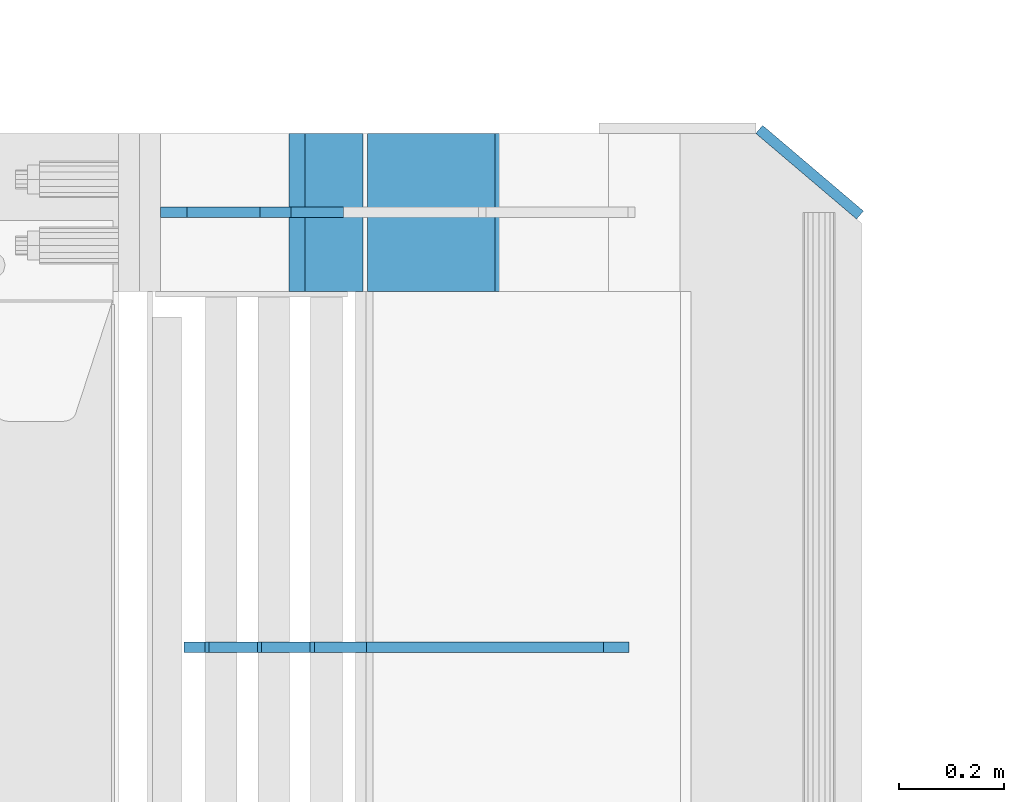
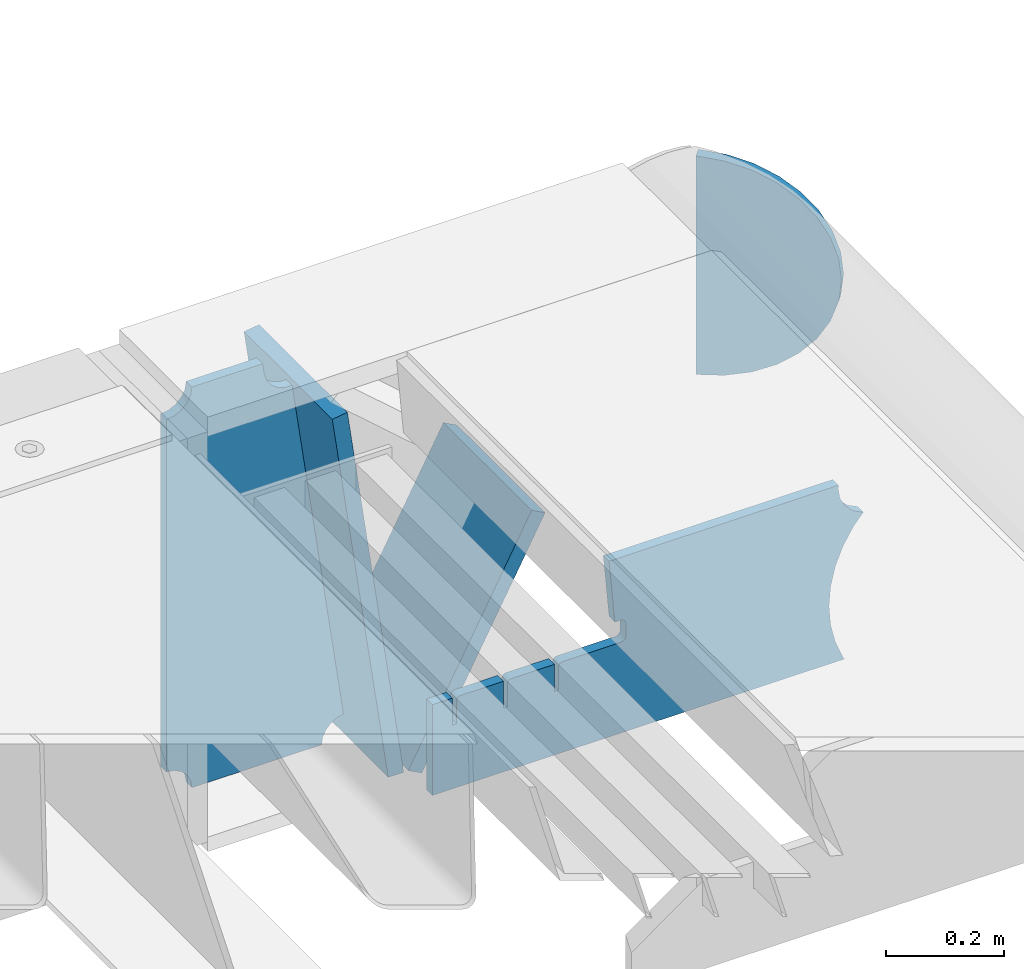
# One storey, part 194 of 208: 5 plates.
"""IFC2X3 building model written with IfcOpenShell, lengths in millimetres."""

from ifc_helpers import new_model, si_unit, frame, origin_with_axes, place, context, subcontext, project, spatial, faceted_brep, material, type_object, element, save


model = new_model("IFC2X3")

# Units and contexts
model_context = context("Model", 3, precision=1e-05, world=origin_with_axes())
body_context = subcontext(model_context, "Body", "Model", "MODEL_VIEW")
ifc_project = project(units=[si_unit("LENGTHUNIT", "METRE", prefix="MILLI"), si_unit("AREAUNIT", "SQUARE_METRE"), si_unit("VOLUMEUNIT", "CUBIC_METRE"), si_unit("MASSUNIT", "GRAM", prefix="KILO"), si_unit("TIMEUNIT", "SECOND"), si_unit("PLANEANGLEUNIT", "RADIAN"), si_unit("SOLIDANGLEUNIT", "STERADIAN"), si_unit("THERMODYNAMICTEMPERATUREUNIT", "DEGREE_CELSIUS"), si_unit("LUMINOUSINTENSITYUNIT", "LUMEN")], contexts=[model_context])

# Site, building, storey
site_placement = place(None, origin_with_axes())
site = spatial("IfcSite", under=ifc_project, at=site_placement, CompositionType="ELEMENT")
building_placement = place(site_placement, origin_with_axes())
building = spatial("IfcBuilding", under=site, at=building_placement, Name="Standard", CompositionType="ELEMENT")
storey_placement = place(building_placement, origin_with_axes())
storey = spatial("IfcBuildingStorey", under=building, at=storey_placement, Name="Undefined", CompositionType="ELEMENT", Elevation=0.0)

# Plates
ifc_material = material(Name="STEEL/S355N")
plate_type_1 = type_object("IfcPlateType", PredefinedType="NOTDEFINED")
plate_1_placement = place(storey_placement, frame((-25183.8519322781, 6150.000000001, -862.083788721732), z_axis=(-0.139173011053008, 0.0, 0.990268081377179), x_axis=(0.0, -1.0, 0.0)))
element("IfcPlate", 1, at=plate_1_placement, inside=storey, type_object=plate_type_1, material=ifc_material, context=body_context, shape_type="Brep", body=[
    faceted_brep([(1.00411057246674e-09, 14.9994702460535, -0.00376939767375006), (300.0, 15.0, 0.0), (300.0, -15.0, 4.21237841386846), (0.0, -15.0, 4.21237841386846), (0.0, -14.9999999999964, 792.0), (300.0, -14.9999999999964, 792.0), (300.0, 15.0, 792.0), (0.0, 15.0, 792.0)], [[[0, 1, 2, 3]], [[4, 5, 6, 7]], [[4, 7, 0, 3]], [[5, 4, 3, 2]], [[6, 5, 2, 1]], [[7, 6, 1, 0]]]),
])
plate_2_placement = place(storey_placement, frame((-25146.7531990434, 6150.000000001, -867.038754739308), z_axis=(0.469471552246176, 0.0, 0.882947598462992), x_axis=(0.0, -1.0, 0.0)))
element("IfcPlate", 2, at=plate_2_placement, inside=storey, type_object=plate_type_1, material=ifc_material, context=body_context, shape_type="Brep", body=[
    faceted_brep([(0.0, -15.0, 0.0), (0.0, -15.0000000000036, 514.999999999996), (0.0, 14.9999999999964, 514.999999999998), (0.0, 15.0, 0.0), (300.0, -15.0000000000036, 514.999999999996), (300.0, 14.9999999999964, 514.999999999998), (300.0, -15.0, 0.0), (300.0, 15.0, 0.0)], [[[0, 1, 2, 3]], [[1, 4, 5, 2]], [[4, 6, 7, 5]], [[6, 0, 3, 7]], [[5, 7, 3, 2]], [[6, 4, 1, 0]]]),
])
plate_type_2 = type_object("IfcPlateType", PredefinedType="NOTDEFINED")
plate_3_placement = place(storey_placement, frame((-25314.001170111, 6000.0, -30.0000000032531), z_axis=(0.0, 0.0, -1.0), x_axis=(-1.0, 0.0, 0.0)))
element("IfcPlate", 3, at=plate_3_placement, inside=storey, type_object=plate_type_2, material=ifc_material, context=body_context, shape_type="Brep", body=[
    faceted_brep([(-9.00602409638668, -10.0, 65.0), (-108.137843376921, -10.0, 780.473130459514), (-108.137843376921, 10.0, 780.473130459514), (-9.00602409638668, 10.0, 65.0), (-94.4157884488377, -10.0, 784.433672138112), (-94.4157884488377, 10.0, 784.433672138112), (-82.3732461236723, -10.0, 792.112074067144), (-82.3732461236723, 10.0, 792.112074067144), (-72.9927947992364, -10.0, 802.881837982249), (-72.9927947992364, 10.0, 802.881837982249), (-67.0398068183713, -10.0, 815.864234368775), (-67.0398068183713, 10.0, 815.864234368775), (-65.0, -10.0, 830.0), (-65.0, 10.0, 830.0), (189.0, -10.0, 830.0), (189.0, 10.0, 830.0), (191.447174185243, -10.0, 814.549150281253), (191.447174185243, 10.0, 814.549150281253), (198.549150281251, -10.0, 800.610737385376), (198.549150281251, 10.0, 800.610737385376), (209.610737385377, -10.0, 789.549150281253), (209.610737385377, 10.0, 789.549150281253), (223.549150281251, -10.0, 782.447174185242), (223.549150281251, 10.0, 782.447174185242), (239.0, -10.0, 780.0), (239.0, 10.0, 780.0), (239.0, -10.0, 50.0), (239.0, 10.0, 50.0), (223.549150281251, -10.0, 47.5528258147577), (223.549150281251, 10.0, 47.5528258147577), (209.610737385377, -10.0, 40.4508497187474), (209.610737385377, 10.0, 40.4508497187474), (198.549150281251, -10.0, 29.3892626146237), (198.549150281251, 10.0, 29.3892626146237), (191.447174185243, -10.0, 15.4508497187474), (191.447174185243, 10.0, 15.4508497187474), (189.0, -10.0, 0.0), (189.0, 10.0, 0.0), (50.4776502774184, -10.0, 0.0), (50.4776502774184, 10.0, 0.0), (47.3830020671812, -10.0, 22.3352870825933), (47.3830020671812, 10.0, 22.3352870825933), (42.8384615202776, -10.0, 37.3040735979326), (42.8384615202776, 10.0, 37.3040735979326), (33.8907372011709, -10.0, 50.1358952937587), (33.8907372011709, 10.0, 50.1358952937587), (21.4156947086703, -10.0, 59.5746840579253), (21.4156947086703, 10.0, 59.5746840579253), (6.63447812067898, -10.0, 64.6965054822873), (6.63447812067898, 10.0, 64.6965054822873)], [[[0, 1, 2, 3]], [[1, 4, 5, 2]], [[4, 6, 7, 5]], [[6, 8, 9, 7]], [[8, 10, 11, 9]], [[10, 12, 13, 11]], [[12, 14, 15, 13]], [[14, 16, 17, 15]], [[16, 18, 19, 17]], [[18, 20, 21, 19]], [[20, 22, 23, 21]], [[22, 24, 25, 23]], [[24, 26, 27, 25]], [[26, 28, 29, 27]], [[28, 30, 31, 29]], [[30, 32, 33, 31]], [[32, 34, 35, 33]], [[34, 36, 37, 35]], [[36, 38, 39, 37]], [[38, 40, 41, 39]], [[40, 42, 43, 41]], [[42, 44, 45, 43]], [[44, 46, 47, 45]], [[46, 48, 49, 47]], [[48, 0, 3, 49]], [[5, 7, 9, 11, 13, 15, 17, 19, 21, 23, 25, 27, 29, 31, 33, 35, 37, 39, 41, 43, 45, 47, 49, 3, 2]], [[48, 46, 44, 42, 40, 38, 36, 34, 32, 30, 28, 26, 24, 22, 20, 18, 16, 14, 12, 10, 8, 6, 4, 1, 0]]]),
])
plate_type_3 = type_object("IfcPlateType", PredefinedType="NOTDEFINED")
plate_4_placement = place(storey_placement, frame((-24667.0817660324, 5174.99928283691, -374.002067436516), z_axis=(0.0, 0.0, 1.0), x_axis=(-1.0, 0.0, 0.0)))
element("IfcPlate", 4, at=plate_4_placement, inside=storey, type_object=plate_type_3, material=ifc_material, context=body_context, shape_type="Brep", body=[
    faceted_brep([(801.919404066546, -10.0, 188.0), (801.919404066546, 10.0, 188.0), (801.919404066546, 10.0000000000001, 132.002067436952), (801.919404066546, -10.0, 132.002067436952), (793.919404066546, 10.0000000000001, 132.002067436952), (793.919404066546, -10.0, 132.002067436952), (793.919404066546, 10.0000000000001, 180.002067436952), (793.919404066546, -10.0, 180.002067436952), (793.527856196906, 10.0000000000001, 182.474203391951), (793.527856196906, -10.0, 182.474203391951), (792.391540021545, 10.0000000000001, 184.704349455291), (792.391540021545, -10.0, 184.704349455291), (790.621686084887, 10.0000000000001, 186.474203391951), (790.621686084887, -10.0, 186.474203391951), (788.391540021545, 10.0000000000001, 187.610519567313), (788.391540021545, -10.0, 187.610519567313), (785.919404066546, -10.0, 188.002067436952), (785.919404066546, 10.0, 188.0), (841.0, -10.0, 188.0), (841.0, -10.0, 0.0), (841.0, 10.0, 0.0), (841.0, 10.0, 188.0), (33.3619566735979, -10.0, 0.0), (33.3619566735979, 10.0, 0.0), (36.2350612208174, -10.0, 4.68848050267007), (36.2350612208174, 10.0, 4.68848050267007), (51.4877592159428, -10.0, 41.5117508652783), (51.4877592159428, 10.0, 41.5117508652783), (60.792242588137, -10.0, 80.2677133162963), (60.792242588137, 10.0, 80.2677133162963), (63.9194040769726, -10.0, 120.002067436515), (63.9194040769726, 10.0, 120.002067436515), (60.792242588137, -10.0, 159.736421556734), (60.792242588137, 10.0, 159.736421556734), (51.4877592159428, -10.0, 198.492384007752), (51.4877592159428, 10.0, 198.492384007752), (36.2350612208174, -10.0, 235.31565437036), (36.2350612208174, 10.0, 235.31565437036), (15.4097206482074, -10.0, 269.299521518803), (15.4097206482074, 10.0, 269.299521518803), (-3.35474438098754, -10.0, 291.269887256574), (-3.35474438098754, 10.0, 291.269887256574), (-2.36881039375294, -10.0, 291.426043859339), (-2.36881039375294, 10.0, 291.426043859339), (17.1449676604716, -10.0, 301.368810393754), (17.1449676604716, 10.0, 301.368810393754), (32.6311896062471, -10.0, 316.855032339527), (32.6311896062471, 10.0, 316.855032339527), (42.573956140659, -10.0, 336.368810393754), (42.573956140659, 10.0, 336.368810393754), (46.0, -10.0, 358.0), (46.0, 10.0, 358.0), (45.0495205499174, -10.0, 364.001091067617), (45.0495205499174, 10.0, 364.001091067617), (495.040008544922, -10.0, 364.010009765625), (495.040008544922, 10.0, 364.010009765625), (483.600036621094, -10.0, 233.759994506836), (483.600036621094, 10.0, 233.759994506836), (472.0, -10.0, 233.759994506836), (472.0, 10.0, 233.759994506836), (468.909830056251, -10.0, 233.270559669787), (468.909830056251, 10.0, 233.270559669787), (466.122147477075, -10.0, 231.850164450585), (466.122147477075, 10.0, 231.850164450585), (463.909830056251, -10.0, 229.637847029761), (463.909830056251, 10.0, 229.637847029761), (462.489434837047, -10.0, 226.850164450585), (462.489434837047, 10.0, 226.850164450585), (462.0, -10.0, 223.759994506836), (462.0, 10.0, 223.759994506836), (462.0, -10.0, 198.0), (462.0, 10.0, 198.0), (462.489434837047, -10.0, 194.909830056251), (462.489434837047, 10.0, 194.909830056251), (463.909830056251, -10.0, 192.122147477075), (463.909830056251, 10.0, 192.122147477075), (466.122147477075, -10.0, 189.909830056251), (466.122147477075, 10.0, 189.909830056251), (468.909830056251, -10.0, 188.489434837048), (468.909830056251, 10.0, 188.489434837048), (472.0, -10.0, 188.0), (472.0, 10.0, 188.0), (585.919404066546, -10.0, 188.002067436952), (585.919404066546, 10.0, 188.0), (588.391540021545, -10.0, 187.610519567313), (588.391540021545, 10.0, 187.610519567313), (590.621686084887, -10.0, 186.474203391951), (590.621686084887, 10.0, 186.474203391951), (592.391540021545, -10.0, 184.704349455291), (592.391540021545, 10.0, 184.704349455291), (593.527856196906, -10.0, 182.474203391951), (593.527856196906, 10.0, 182.474203391951), (593.919404066546, -10.0, 180.002067436952), (593.919404066546, 10.0, 180.002067436952), (593.919404066546, -10.0, 132.002067436952), (593.919404066546, 10.0, 132.002067436952), (601.919404066546, -10.0, 132.002067436952), (601.919404066546, 10.0, 132.002067436952), (601.919404066546, -10.0, 188.0), (601.919404066546, 10.0, 188.0), (685.919404066546, -10.0, 188.002067436952), (685.919404066546, 10.0, 188.0), (688.391540021545, -10.0, 187.610519567313), (688.391540021545, 10.0, 187.610519567313), (690.621686084887, -10.0, 186.474203391951), (690.621686084887, 10.0, 186.474203391951), (692.391540021545, -10.0, 184.704349455291), (692.391540021545, 10.0, 184.704349455291), (693.527856196906, -10.0, 182.474203391951), (693.527856196906, 10.0, 182.474203391951), (693.919404066546, -10.0, 180.002067436952), (693.919404066546, 10.0, 180.002067436952), (693.919404066546, -10.0, 132.002067436952), (693.919404066546, 9.99999999999989, 132.002067436952), (701.919404066546, -10.0, 132.002067436952), (701.919404066546, 9.99999999999989, 132.002067436952), (701.919404066546, -10.0, 188.0), (701.919404066546, 10.0, 188.0)], [[[0, 1, 2, 3]], [[3, 2, 4, 5]], [[5, 4, 6, 7]], [[7, 6, 8, 9]], [[9, 8, 10, 11]], [[11, 10, 12, 13]], [[13, 12, 14, 15]], [[16, 15, 14, 17]], [[18, 19, 20, 21]], [[20, 19, 22, 23]], [[22, 24, 25, 23]], [[26, 27, 25, 24]], [[28, 29, 27, 26]], [[30, 31, 29, 28]], [[32, 33, 31, 30]], [[34, 35, 33, 32]], [[36, 37, 35, 34]], [[38, 39, 37, 36]], [[39, 38, 40, 41]], [[40, 42, 43, 41]], [[44, 45, 43, 42]], [[46, 47, 45, 44]], [[48, 49, 47, 46]], [[50, 51, 49, 48]], [[52, 53, 51, 50]], [[54, 55, 53, 52]], [[54, 56, 57, 55]], [[56, 58, 59, 57]], [[58, 60, 61, 59]], [[60, 62, 63, 61]], [[62, 64, 65, 63]], [[64, 66, 67, 65]], [[66, 68, 69, 67]], [[68, 70, 71, 69]], [[70, 72, 73, 71]], [[72, 74, 75, 73]], [[74, 76, 77, 75]], [[76, 78, 79, 77]], [[78, 80, 81, 79]], [[81, 80, 82, 83]], [[82, 84, 85, 83]], [[86, 87, 85, 84]], [[88, 89, 87, 86]], [[90, 91, 89, 88]], [[92, 93, 91, 90]], [[94, 95, 93, 92]], [[96, 97, 95, 94]], [[98, 99, 97, 96]], [[99, 98, 100, 101]], [[100, 102, 103, 101]], [[104, 105, 103, 102]], [[106, 107, 105, 104]], [[108, 109, 107, 106]], [[110, 111, 109, 108]], [[112, 113, 111, 110]], [[114, 115, 113, 112]], [[116, 117, 115, 114]], [[117, 116, 16, 17]], [[12, 10, 8, 6, 4, 2, 1, 21, 20, 23, 25, 27, 29, 31, 33, 35, 37, 39, 41, 43, 45, 47, 49, 51, 53, 55, 57, 59, 61, 63, 65, 67, 69, 71, 73, 75, 77, 79, 81, 83, 85, 87, 89, 91, 93, 95, 97, 99, 101, 103, 105, 107, 109, 111, 113, 115, 117, 17, 14]], [[18, 21, 1, 0]], [[116, 114, 112, 110, 108, 106, 104, 102, 100, 98, 96, 94, 92, 90, 88, 86, 84, 82, 80, 78, 76, 74, 72, 70, 68, 66, 64, 62, 60, 58, 56, 54, 52, 50, 48, 46, 44, 42, 40, 38, 36, 34, 32, 30, 28, 26, 24, 22, 19, 18, 0, 3, 5, 7, 9, 11, 13, 15, 16]]]),
])
plate_type_4 = type_object("IfcPlateType", PredefinedType="NOTDEFINED")
plate_5_placement = place(storey_placement, frame((-24379.3319447428, 6125.95314920567, -30.6119535183306), z_axis=(-0.0673151699806107, 0.0572188599835174, -0.996089689713064), x_axis=(-0.758954680570056, 0.64512205263455, 0.0883477789499519)))
element("IfcPlate", 5, at=plate_5_placement, inside=storey, type_object=plate_type_4, material=ifc_material, context=body_context, shape_type="Brep", body=[
    faceted_brep([(0.0, -10.0, 0.0), (-48.0501251221685, -10.0000000000036, 8.67006015777611), (-48.0501251221685, 9.99999999999818, 8.67006015777588), (0.0, 10.0, 0.0), (-93.1325836184478, -10.0, 25.6772422790527), (-93.1325836184515, 10.0, 25.6772422790527), (-133.519607544506, -10.0000000000018, 50.3672103881836), (-133.519607544498, 9.99999999999454, 50.3672103881836), (-167.654617310473, -10.0000000000018, 81.7923126220703), (-167.654617310476, 9.99999999999818, 81.7923126220703), (-194.116653443692, -10.0000000000018, 118.75399017334), (-194.116653443692, 10.0, 118.75399017334), (-212.21937561212, -10.0, 159.802307128906), (-212.219375612116, 10.0, 159.802307128906), (-220.935668947557, -10.0000000000018, 203.390228271484), (-220.935668947557, 10.0, 203.390228271484), (-220.042388918751, -10.0000000000055, 247.831420898438), (-220.042388918751, 9.99999999999636, 247.831420898438), (-209.448760989548, -10.0000000000036, 291.430206298828), (-209.448760989548, 9.99999999999636, 291.430206298828), (-189.931198123788, -10.0000000000018, 332.477691650391), (-189.931198123788, 10.0, 332.477691650391), (-161.872329715996, -10.0000000000036, 369.429595947266), (-161.872329715992, 9.99999999999818, 369.429595947266), (-126.473861698763, -10.0, 400.854248046875), (-126.47386169876, 10.0, 400.854248046875), (-85.0954742478643, -10.0, 425.544403076172), (-85.0954742478607, 9.99999999999636, 425.544403076172), (-39.326648717044, -10.0000000000036, 442.551971435547), (-39.326648717044, 9.99999999999636, 442.551971435547), (9.07161902882945, -10.0000000000018, 451.221954345703), (9.07161902882945, 9.99999999999818, 451.221954345703), (49.1691665649414, -10.0000000000055, 5.16138243256137e-11), (49.1691665649378, 9.99999999999818, 5.13864506501704e-11)], [[[0, 1, 2, 3]], [[1, 4, 5, 2]], [[4, 6, 7, 5]], [[6, 8, 9, 7]], [[8, 10, 11, 9]], [[10, 12, 13, 11]], [[12, 14, 15, 13]], [[14, 16, 17, 15]], [[16, 18, 19, 17]], [[18, 20, 21, 19]], [[20, 22, 23, 21]], [[22, 24, 25, 23]], [[24, 26, 27, 25]], [[26, 28, 29, 27]], [[28, 30, 31, 29]], [[30, 32, 33, 31]], [[32, 0, 3, 33]], [[5, 7, 9, 11, 13, 15, 17, 19, 21, 23, 25, 27, 29, 31, 33, 3, 2]], [[32, 30, 28, 26, 24, 22, 20, 18, 16, 14, 12, 10, 8, 6, 4, 1, 0]]]),
])

save(model, "model.ifc")
